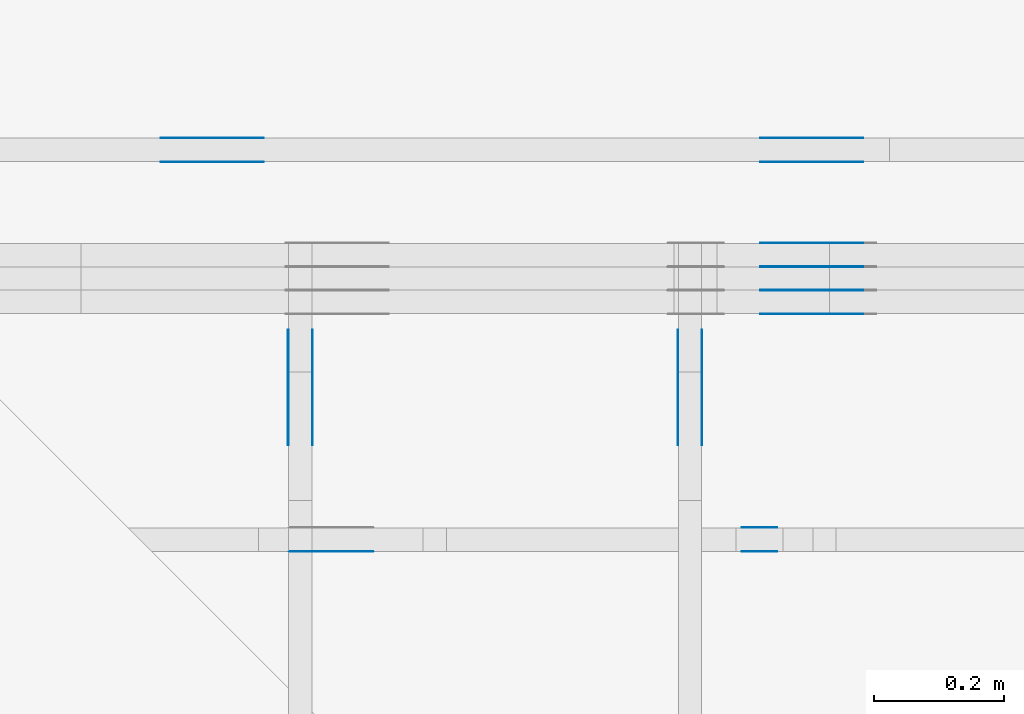
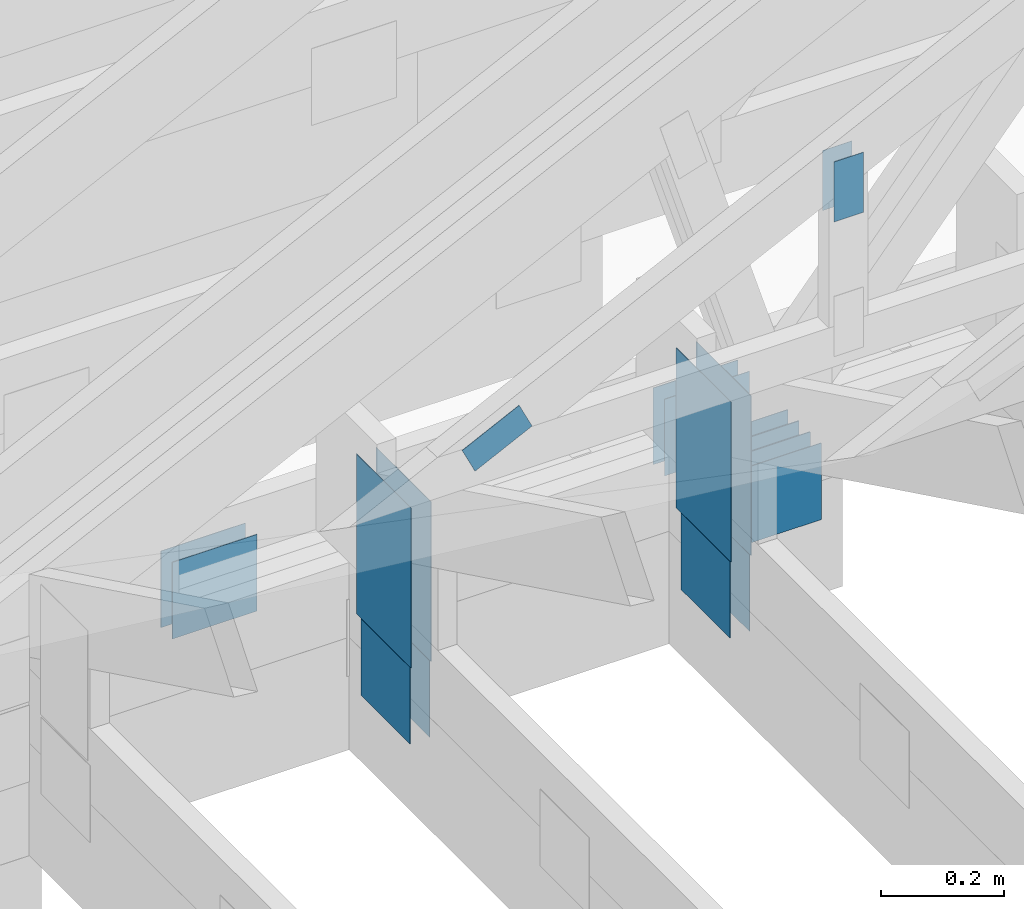
# One storey, part 100 of 159: 21 plates, 5 elements without a shape of their own.
"""IFC2X3 building model written with IfcOpenShell, lengths in millimetres."""

import ifcopenshell
import ifcopenshell.guid

model = None  # the IFC model being written
_history = None  # IfcOwnerHistory: only IFC2X3 demands one
_inside = {}  # id of a spatial element -> (the spatial element, [elements in it])
_under = {}  # id of a project, library or spatial element -> (it, [spatial elements below it])
_declared = {}  # id of a project -> (the project, [libraries it declares])
_typed = {}  # id of a type object -> (the type object, [elements of that type])
_made_of = {}  # id of a material, layer set ... -> (it, [elements and type objects made of it])


def new_model(schema):
    """Start an empty IFC model of exactly this schema.

    Asked for "IFC4X3", IfcOpenShell would pick the latest addendum, in which some entities
    have other attributes; the version numbers below select the first issue.
    IFC2X3 requires an IfcOwnerHistory on every rooted entity: one is made here for all.
    """
    global model, _history
    if schema == "IFC4X3":
        model = ifcopenshell.file(schema_version=(4, 3, 0, 0))
    else:
        model = ifcopenshell.file(schema=schema)
    _inside.clear()
    _under.clear()
    _declared.clear()
    _typed.clear()
    _made_of.clear()
    _history = None
    if model.schema == "IFC2X3":
        org = make("IfcOrganization", Name="unknown")
        user = make(
            "IfcPersonAndOrganization",
            ThePerson=make("IfcPerson", FamilyName="unknown"),
            TheOrganization=org,
        )
        app = make(
            "IfcApplication",
            ApplicationDeveloper=org,
            Version="unknown",
            ApplicationFullName="unknown",
            ApplicationIdentifier="unknown",
        )
        _history = make(
            "IfcOwnerHistory",
            OwningUser=user,
            OwningApplication=app,
            ChangeAction="ADDED",
            CreationDate=0,
        )
    return model


def make(cls, **values):
    """One entity of the class cls with the attributes given. An attribute that is None is left unset."""
    return model.create_entity(
        cls, **{name: value for name, value in values.items() if value is not None}
    )


def rooted(cls, **values):
    """An entity with a GlobalId (a new one), such as an element, a storey or a relation."""
    return make(cls, GlobalId=ifcopenshell.guid.new(), OwnerHistory=_history, **values)


def si_unit(unit_type, name, prefix=None):
    """IfcSIUnit, for example si_unit("LENGTHUNIT", "METRE", prefix="MILLI")."""
    return make("IfcSIUnit", UnitType=unit_type, Prefix=prefix, Name=name)


def assignment(units):
    """IfcUnitAssignment: the units of a project."""
    return None if units is None else make("IfcUnitAssignment", Units=units)


def point(xyz):
    """IfcCartesianPoint."""
    return None if xyz is None else make("IfcCartesianPoint", Coordinates=xyz)


def direction(xyz):
    """IfcDirection."""
    return None if xyz is None else make("IfcDirection", DirectionRatios=xyz)


def frame(location, z_axis=None, x_axis=None):
    """IfcAxis2Placement3D, a coordinate frame: its origin and axes. An axis left out is left unset."""
    return make(
        "IfcAxis2Placement3D",
        Location=point(location),
        Axis=direction(z_axis),
        RefDirection=direction(x_axis),
    )


def frame_2d(location, x_axis=None):
    """IfcAxis2Placement2D, a coordinate frame in the plane: its origin and x axis."""
    return make(
        "IfcAxis2Placement2D", Location=point(location), RefDirection=direction(x_axis)
    )


def origin():
    """The frame at (0, 0, 0) with its axes left unset."""
    return frame((0.0, 0.0, 0.0))


def origin_with_axes():
    """The frame at (0, 0, 0) with the z axis (0, 0, 1) and the x axis (1, 0, 0) written out."""
    return frame((0.0, 0.0, 0.0), z_axis=(0.0, 0.0, 1.0), x_axis=(1.0, 0.0, 0.0))


def origin_2d():
    """The frame at (0, 0) in the plane with its x axis left unset."""
    return frame_2d((0.0, 0.0))


def place(relative_to, where):
    """IfcLocalPlacement: puts the frame where relative to a parent placement (None: the world)."""
    return make(
        "IfcLocalPlacement", PlacementRelTo=relative_to, RelativePlacement=where
    )


def context(
    kind, dimensions, precision=None, world=None, true_north=None, identifier=None
):
    """IfcGeometricRepresentationContext, for example the 3D "Model" context."""
    return make(
        "IfcGeometricRepresentationContext",
        ContextIdentifier=identifier,
        ContextType=kind,
        CoordinateSpaceDimension=dimensions,
        Precision=precision,
        WorldCoordinateSystem=world,
        TrueNorth=true_north,
    )


def project(units=None, contexts=None):
    """IfcProject with its units and contexts."""
    return rooted(
        "IfcProject",
        Name="project",
        RepresentationContexts=contexts,
        UnitsInContext=assignment(units),
    )


def spatial(cls, under=None, at=None, **own):
    """A site, building, storey or space (cls), placed at a placement, below another one or the project."""
    s = rooted(cls, ObjectPlacement=at, **own)
    if under is not None:
        _under.setdefault(under.id(), (under, []))[1].append(s)
    return s


def faces_of(points, faces, orient=None, outer=None):
    """IfcFace entities. A face is a list of loops; a loop is a list of indices into points, from 0.

    orient and outer hold one flag for each loop. By default every Orientation is true, the
    first loop of a face is its IfcFaceOuterBound and the others are IfcFaceBound.
    """
    made = []
    for i, loops in enumerate(faces):
        bounds = []
        for j, loop in enumerate(loops):
            is_outer = j == 0 if outer is None else outer[i][j]
            bounds.append(
                make(
                    "IfcFaceOuterBound" if is_outer else "IfcFaceBound",
                    Bound=make("IfcPolyLoop", Polygon=[points[k] for k in loop]),
                    Orientation=True if orient is None else orient[i][j],
                )
            )
        made.append(make("IfcFace", Bounds=bounds))
    return made


def faceted_brep(points, faces, orient=None, outer=None, voids=None):
    """IfcFacetedBrep: a solid bounded by flat faces; with voids (closed shells), ...WithVoids."""
    shared = [point(p) for p in points]
    hull = make("IfcClosedShell", CfsFaces=faces_of(shared, faces, orient, outer))
    if voids is None:
        return make("IfcFacetedBrep", Outer=hull)
    return make(
        "IfcFacetedBrepWithVoids",
        Outer=hull,
        Voids=[
            make(cls, CfsFaces=faces_of(shared, fs, o, b)) for cls, fs, o, b in voids
        ],
    )


def shape(context_of_items, identifier, shape_type, items):
    """IfcShapeRepresentation: the items that make up one representation, for example the "Body"."""
    return make(
        "IfcShapeRepresentation",
        ContextOfItems=context_of_items,
        RepresentationIdentifier=identifier,
        RepresentationType=shape_type,
        Items=items,
    )


def made_of(thing, what):
    """Note that an element or type object is made of a material, layer set ...; save() writes the relation."""
    if what is not None:
        _made_of.setdefault(what.id(), (what, []))[1].append(thing)
    return thing


def element(
    cls,
    number,
    at=None,
    inside=None,
    cuts=None,
    type_object=None,
    material=None,
    context=None,
    identifier="Body",
    shape_type=None,
    held_by="IfcProductDefinitionShape",
    body=None,
    shapes=None,
    **own,
):
    """One element of the class cls, such as IfcWall. Its Tag is "e" and its number.

    at: its placement. inside: the storey or other place that contains it. cuts: it is an
    opening in that element (IfcRelVoidsElement). A single representation is given by context,
    identifier, shape_type and body (its items); several are given by shapes. held_by: the class
    of the entity that holds the representations. save() writes the other relations.
    """
    e = rooted(cls, Tag="e%d" % number, ObjectPlacement=at, **own)
    if body is not None:
        shapes = [shape(context, identifier, shape_type, body)]
    if shapes is not None:
        e.Representation = make(held_by, Representations=shapes)
    if inside is not None:
        _inside.setdefault(inside.id(), (inside, []))[1].append(e)
    if cuts is not None:
        rooted(
            "IfcRelVoidsElement", RelatingBuildingElement=cuts, RelatedOpeningElement=e
        )
    if type_object is not None:
        _typed.setdefault(type_object.id(), (type_object, []))[1].append(e)
    return made_of(e, material)


def aggregate(whole, parts):
    """IfcRelAggregates: a whole, such as a stair, and the parts it consists of."""
    return rooted("IfcRelAggregates", RelatingObject=whole, RelatedObjects=parts)


def save(model, path):
    """Write the relations noted so far, then the file.

    IfcRelAggregates (storeys below a building ...), IfcRelContainedInSpatialStructure (elements
    in a storey), IfcRelDefinesByType, IfcRelAssociatesMaterial and IfcRelDeclares: one each for
    every whole, place, type object, material and project.
    """
    for whole, parts in _under.values():
        aggregate(whole, parts)
    for where, things in _inside.values():
        rooted(
            "IfcRelContainedInSpatialStructure",
            RelatedElements=things,
            RelatingStructure=where,
        )
    for kind, things in _typed.values():
        rooted("IfcRelDefinesByType", RelatedObjects=things, RelatingType=kind)
    for what, things in _made_of.values():
        rooted("IfcRelAssociatesMaterial", RelatedObjects=things, RelatingMaterial=what)
    for by, libraries in _declared.values():
        rooted("IfcRelDeclares", RelatingContext=by, RelatedDefinitions=libraries)
    model.write(path)


model = new_model("IFC2X3")

# Units and contexts
model_context = context("Model", 3, precision=1e-05, world=origin())
plan_context = context("Plan", 2, precision=1e-05, world=origin_2d())
ifc_project = project(units=[si_unit("LENGTHUNIT", "METRE", prefix="MILLI"), si_unit("AREAUNIT", "SQUARE_METRE"), si_unit("VOLUMEUNIT", "CUBIC_METRE"), si_unit("SOLIDANGLEUNIT", "STERADIAN"), si_unit("PLANEANGLEUNIT", "RADIAN"), si_unit("MASSUNIT", "GRAM"), si_unit("TIMEUNIT", "SECOND"), si_unit("THERMODYNAMICTEMPERATUREUNIT", "DEGREE_CELSIUS"), si_unit("LUMINOUSINTENSITYUNIT", "LUMEN")], contexts=[model_context, plan_context])

# Site, building, storey
site_placement = place(None, origin_with_axes())
site = spatial("IfcSite", under=ifc_project, at=site_placement, CompositionType="ELEMENT")
building_placement = place(site_placement, origin_with_axes())
building = spatial("IfcBuilding", under=site, at=building_placement, Name="Plan 1", CompositionType="ELEMENT")
storey_placement = place(building_placement, origin_with_axes())
storey = spatial("IfcBuildingStorey", under=building, at=storey_placement, Name="Etasje 1", CompositionType="ELEMENT", Elevation=0.0)

# Assembly, plates
assembly_1_placement = place(storey_placement, frame((10700.012663101485, 8801.999999990367, 0.0), z_axis=(0.0, -1.0, 6.123031769111886e-17), x_axis=(1.0, 0.0, 0.0)))
assembly_1 = element("IfcElementAssembly", 1, at=assembly_1_placement, inside=storey, Name="T8 (1)", AssemblyPlace="FACTORY", PredefinedType="TRUSS")
plate_1_placement = place(assembly_1_placement, frame((1660.0, 299.0, 0.0), z_axis=(0.0, 0.0, 1.0), x_axis=(-1.0, 1.2246063538223773e-16, 0.0)))
plate_1 = element("IfcPlate", 2, at=plate_1_placement, Name="GNT100S 152x159", context=model_context, shape_type="Brep", body=[
    faceted_brep([(159.0, 152.00000000000003, 1.0), (0.0, 152.00000000000003, 1.0), (0.0, 0.0, 1.0), (159.0, 0.0, 1.0), (0.0, 152.00000000000003, 0.0), (159.0, 152.00000000000003, 1.9471241025775798e-14), (159.0, 5.684341886080802e-14, 1.9471241025775798e-14), (0.0, 5.684341886080802e-14, 0.0), (159.0, -2.92068615386637e-14, 5.2688860062695115e-30), (159.0, -2.914563122097258e-14, 1.0), (1.1247455413666031e-32, 6.123031769111886e-17, 1.0), (0.0, 0.0, 0.0), (159.0, 152.00000000000006, 0.0), (159.0, 152.00000000000006, 1.0), (159.0, 5.684341886080802e-14, 1.0), (159.0, 5.684341886080802e-14, 0.0), (0.0, 152.00000000000003, 0.0), (0.0, 152.00000000000003, 1.0), (159.0, 152.00000000000006, 1.0), (159.0, 152.00000000000006, 0.0), (0.0, 0.0, 0.0), (6.123031769111886e-17, -7.498303609110687e-33, 1.0), (1.8675246895791256e-14, 152.00000000000003, 1.0), (1.8614016578100137e-14, 152.00000000000003, -1.1397421485848246e-30)], [[[0, 1, 2, 3]], [[4, 5, 6, 7]], [[8, 9, 10, 11]], [[12, 13, 14, 15]], [[16, 17, 18, 19]], [[20, 21, 22, 23]]]),
])
plate_2_placement = place(assembly_1_placement, frame((1660.0, 299.0, -37.0), z_axis=(0.0, 0.0, 1.0), x_axis=(-1.0, 1.2246063538223773e-16, 0.0)))
plate_2 = element("IfcPlate", 3, at=plate_2_placement, Name="GNT100S 152x159", context=model_context, shape_type="Brep", body=[
    faceted_brep([(159.0, 152.00000000000003, 1.0), (0.0, 152.00000000000003, 1.0), (0.0, 0.0, 1.0), (159.0, 0.0, 1.0), (0.0, 152.00000000000003, 0.0), (159.0, 152.00000000000003, 1.9471241025775798e-14), (159.0, 5.684341886080802e-14, 1.9471241025775798e-14), (0.0, 5.684341886080802e-14, 0.0), (159.0, -2.92068615386637e-14, 5.2688860062695115e-30), (159.0, -2.914563122097258e-14, 1.0), (1.1247455413666031e-32, 6.123031769111886e-17, 1.0), (0.0, 0.0, 0.0), (159.0, 152.00000000000006, 0.0), (159.0, 152.00000000000006, 1.0), (159.0, 5.684341886080802e-14, 1.0), (159.0, 5.684341886080802e-14, 0.0), (0.0, 152.00000000000003, 0.0), (0.0, 152.00000000000003, 1.0), (159.0, 152.00000000000006, 1.0), (159.0, 152.00000000000006, 0.0), (0.0, 0.0, 0.0), (6.123031769111886e-17, -7.498303609110687e-33, 1.0), (1.8675246895791256e-14, 152.00000000000003, 1.0), (1.8614016578100137e-14, 152.00000000000003, -1.1397421485848246e-30)], [[[0, 1, 2, 3]], [[4, 5, 6, 7]], [[8, 9, 10, 11]], [[12, 13, 14, 15]], [[16, 17, 18, 19]], [[20, 21, 22, 23]]]),
])
plate_3_placement = place(assembly_1_placement, frame((1660.0, 299.0, -36.0), z_axis=(0.0, 0.0, 1.0), x_axis=(-1.0, 1.2246063538223773e-16, 0.0)))
plate_3 = element("IfcPlate", 4, at=plate_3_placement, Name="GNT100S 152x159", context=model_context, shape_type="Brep", body=[
    faceted_brep([(159.0, 152.00000000000003, 1.0), (0.0, 152.00000000000003, 1.0), (0.0, 0.0, 1.0), (159.0, 0.0, 1.0), (0.0, 152.00000000000003, 0.0), (159.0, 152.00000000000003, 1.9471241025775798e-14), (159.0, 5.684341886080802e-14, 1.9471241025775798e-14), (0.0, 5.684341886080802e-14, 0.0), (159.0, -2.92068615386637e-14, 5.2688860062695115e-30), (159.0, -2.914563122097258e-14, 1.0), (1.1247455413666031e-32, 6.123031769111886e-17, 1.0), (0.0, 0.0, 0.0), (159.0, 152.00000000000006, 0.0), (159.0, 152.00000000000006, 1.0), (159.0, 5.684341886080802e-14, 1.0), (159.0, 5.684341886080802e-14, 0.0), (0.0, 152.00000000000003, 0.0), (0.0, 152.00000000000003, 1.0), (159.0, 152.00000000000006, 1.0), (159.0, 152.00000000000006, 0.0), (0.0, 0.0, 0.0), (6.123031769111886e-17, -7.498303609110687e-33, 1.0), (1.8675246895791256e-14, 152.00000000000003, 1.0), (1.8614016578100137e-14, 152.00000000000003, -1.1397421485848246e-30)], [[[0, 1, 2, 3]], [[4, 5, 6, 7]], [[8, 9, 10, 11]], [[12, 13, 14, 15]], [[16, 17, 18, 19]], [[20, 21, 22, 23]]]),
])
plate_4_placement = place(assembly_1_placement, frame((1660.0, 299.0, -73.0), z_axis=(0.0, 0.0, 1.0), x_axis=(-1.0, 1.2246063538223773e-16, 0.0)))
plate_4 = element("IfcPlate", 5, at=plate_4_placement, Name="GNT100S 152x159", context=model_context, shape_type="Brep", body=[
    faceted_brep([(159.0, 152.00000000000003, 1.0), (0.0, 152.00000000000003, 1.0), (0.0, 0.0, 1.0), (159.0, 0.0, 1.0), (0.0, 152.00000000000003, 0.0), (159.0, 152.00000000000003, 1.9471241025775798e-14), (159.0, 5.684341886080802e-14, 1.9471241025775798e-14), (0.0, 5.684341886080802e-14, 0.0), (159.0, -2.92068615386637e-14, 5.2688860062695115e-30), (159.0, -2.914563122097258e-14, 1.0), (1.1247455413666031e-32, 6.123031769111886e-17, 1.0), (0.0, 0.0, 0.0), (159.0, 152.00000000000006, 0.0), (159.0, 152.00000000000006, 1.0), (159.0, 5.684341886080802e-14, 1.0), (159.0, 5.684341886080802e-14, 0.0), (0.0, 152.00000000000003, 0.0), (0.0, 152.00000000000003, 1.0), (159.0, 152.00000000000006, 1.0), (159.0, 152.00000000000006, 0.0), (0.0, 0.0, 0.0), (6.123031769111886e-17, -7.498303609110687e-33, 1.0), (1.8675246895791256e-14, 152.00000000000003, 1.0), (1.8614016578100137e-14, 152.00000000000003, -1.1397421485848246e-30)], [[[0, 1, 2, 3]], [[4, 5, 6, 7]], [[8, 9, 10, 11]], [[12, 13, 14, 15]], [[16, 17, 18, 19]], [[20, 21, 22, 23]]]),
])
plate_5_placement = place(assembly_1_placement, frame((1660.0, 299.0, -72.0), z_axis=(0.0, 0.0, 1.0), x_axis=(-1.0, 1.2246063538223773e-16, 0.0)))
plate_5 = element("IfcPlate", 6, at=plate_5_placement, Name="GNT100S 152x159", context=model_context, shape_type="Brep", body=[
    faceted_brep([(159.0, 152.00000000000003, 1.0), (0.0, 152.00000000000003, 1.0), (0.0, 0.0, 1.0), (159.0, 0.0, 1.0), (0.0, 152.00000000000003, 0.0), (159.0, 152.00000000000003, 1.9471241025775798e-14), (159.0, 5.684341886080802e-14, 1.9471241025775798e-14), (0.0, 5.684341886080802e-14, 0.0), (159.0, -2.92068615386637e-14, 5.2688860062695115e-30), (159.0, -2.914563122097258e-14, 1.0), (1.1247455413666031e-32, 6.123031769111886e-17, 1.0), (0.0, 0.0, 0.0), (159.0, 152.00000000000006, 0.0), (159.0, 152.00000000000006, 1.0), (159.0, 5.684341886080802e-14, 1.0), (159.0, 5.684341886080802e-14, 0.0), (0.0, 152.00000000000003, 0.0), (0.0, 152.00000000000003, 1.0), (159.0, 152.00000000000006, 1.0), (159.0, 152.00000000000006, 0.0), (0.0, 0.0, 0.0), (6.123031769111886e-17, -7.498303609110687e-33, 1.0), (1.8675246895791256e-14, 152.00000000000003, 1.0), (1.8614016578100137e-14, 152.00000000000003, -1.1397421485848246e-30)], [[[0, 1, 2, 3]], [[4, 5, 6, 7]], [[8, 9, 10, 11]], [[12, 13, 14, 15]], [[16, 17, 18, 19]], [[20, 21, 22, 23]]]),
])
plate_6_placement = place(assembly_1_placement, frame((1660.0, 299.0, -109.0), z_axis=(0.0, 0.0, 1.0), x_axis=(-1.0, 1.2246063538223773e-16, 0.0)))
plate_6 = element("IfcPlate", 7, at=plate_6_placement, Name="GNT100S 152x159", context=model_context, shape_type="Brep", body=[
    faceted_brep([(159.0, 152.00000000000003, 1.0), (0.0, 152.00000000000003, 1.0), (0.0, 0.0, 1.0), (159.0, 0.0, 1.0), (0.0, 152.00000000000003, 0.0), (159.0, 152.00000000000003, 1.9471241025775798e-14), (159.0, 5.684341886080802e-14, 1.9471241025775798e-14), (0.0, 5.684341886080802e-14, 0.0), (159.0, -2.92068615386637e-14, 5.2688860062695115e-30), (159.0, -2.914563122097258e-14, 1.0), (1.1247455413666031e-32, 6.123031769111886e-17, 1.0), (0.0, 0.0, 0.0), (159.0, 152.00000000000006, 0.0), (159.0, 152.00000000000006, 1.0), (159.0, 5.684341886080802e-14, 1.0), (159.0, 5.684341886080802e-14, 0.0), (0.0, 152.00000000000003, 0.0), (0.0, 152.00000000000003, 1.0), (159.0, 152.00000000000006, 1.0), (159.0, 152.00000000000006, 0.0), (0.0, 0.0, 0.0), (6.123031769111886e-17, -7.498303609110687e-33, 1.0), (1.8675246895791256e-14, 152.00000000000003, 1.0), (1.8614016578100137e-14, 152.00000000000003, -1.1397421485848246e-30)], [[[0, 1, 2, 3]], [[4, 5, 6, 7]], [[8, 9, 10, 11]], [[12, 13, 14, 15]], [[16, 17, 18, 19]], [[20, 21, 22, 23]]]),
])
aggregate(assembly_1, [plate_1, plate_2, plate_3, plate_4, plate_5, plate_6])

assembly_2_placement = place(storey_placement, frame((10000.012663278096, 9072.000080051337, 1.1021457184401395e-15), z_axis=(9.811600543477555e-09, 1.0, 6.123031769111886e-17), x_axis=(-1.0, 9.811600543477555e-09, 0.0)))
assembly_2 = element("IfcElementAssembly", 8, at=assembly_2_placement, inside=storey, Name="T9 (79)", AssemblyPlace="FACTORY", PredefinedType="TRUSS")
plate_7_placement = place(assembly_2_placement, frame((-2360.0, 147.0, 0.0), z_axis=(0.0, 0.0, 1.0), x_axis=(1.0, 0.0, 0.0)))
plate_7 = element("IfcPlate", 9, at=plate_7_placement, Name="GNT100S 152x159", context=model_context, shape_type="Brep", body=[
    faceted_brep([(159.0, 152.0, 1.0), (0.0, 152.0, 1.0), (0.0, 0.0, 1.0), (159.0, 0.0, 1.0), (0.0, 152.0, 0.0), (159.0, 152.0, 1.9471241025775798e-14), (159.0, 0.0, 1.9471241025775798e-14), (0.0, 0.0, 0.0), (159.0, 3.373933274962177e-10, 1.788345410772899e-30), (159.0, 3.373933887265354e-10, 1.0), (1.1247455413666031e-32, 3.3742259558807407e-10, 1.0), (0.0, 3.374225343577564e-10, 0.0), (159.0, 152.00000000033742, 0.0), (159.0, 152.00000000033742, 1.0), (159.0, 3.374225343577564e-10, 1.0), (159.0, 3.374225343577564e-10, 0.0), (0.0, 152.00000000033742, 0.0), (-3.7491518045553436e-33, 152.00000000033742, 1.0), (159.0, 152.00000000033742, 1.0), (159.0, 152.00000000033742, 0.0), (4.1320977949735785e-26, 3.374225343577564e-10, -2.5300966071700395e-42), (6.123031773243984e-17, 3.374225343577564e-10, 1.0), (1.8675246895832574e-14, 152.00000000033742, 1.0), (1.8614016578141455e-14, 152.00000000033742, -1.1397421485873545e-30)], [[[0, 1, 2, 3]], [[4, 5, 6, 7]], [[8, 9, 10, 11]], [[12, 13, 14, 15]], [[16, 17, 18, 19]], [[20, 21, 22, 23]]]),
])
plate_8_placement = place(assembly_2_placement, frame((-2360.0, 147.0, -37.0), z_axis=(0.0, 0.0, 1.0), x_axis=(1.0, 0.0, 0.0)))
plate_8 = element("IfcPlate", 10, at=plate_8_placement, Name="GNT100S 152x159", context=model_context, shape_type="Brep", body=[
    faceted_brep([(159.0, 152.0, 1.0), (0.0, 152.0, 1.0), (0.0, 0.0, 1.0), (159.0, 0.0, 1.0), (0.0, 152.0, 0.0), (159.0, 152.0, 1.9471241025775798e-14), (159.0, 0.0, 1.9471241025775798e-14), (0.0, 0.0, 0.0), (159.0, 3.373933274962177e-10, 1.788345410772899e-30), (159.0, 3.373933887265354e-10, 1.0), (1.1247455413666031e-32, 3.3742259558807407e-10, 1.0), (0.0, 3.374225343577564e-10, 0.0), (159.0, 152.00000000033742, 0.0), (159.0, 152.00000000033742, 1.0), (159.0, 3.374225343577564e-10, 1.0), (159.0, 3.374225343577564e-10, 0.0), (0.0, 152.00000000033742, 0.0), (-3.7491518045553436e-33, 152.00000000033742, 1.0), (159.0, 152.00000000033742, 1.0), (159.0, 152.00000000033742, 0.0), (4.1320977949735785e-26, 3.374225343577564e-10, -2.5300966071700395e-42), (6.123031773243984e-17, 3.374225343577564e-10, 1.0), (1.8675246895832574e-14, 152.00000000033742, 1.0), (1.8614016578141455e-14, 152.00000000033742, -1.1397421485873545e-30)], [[[0, 1, 2, 3]], [[4, 5, 6, 7]], [[8, 9, 10, 11]], [[12, 13, 14, 15]], [[16, 17, 18, 19]], [[20, 21, 22, 23]]]),
])
plate_9_placement = place(assembly_2_placement, frame((-1436.851318359375, 147.0, 0.0), z_axis=(0.0, 0.0, 1.0), x_axis=(1.0, 0.0, 0.0)))
plate_9 = element("IfcPlate", 11, at=plate_9_placement, Name="GNT100S 152x159", context=model_context, shape_type="Brep", body=[
    faceted_brep([(159.0, 152.0, 1.0), (0.0, 152.0, 1.0), (0.0, 0.0, 1.0), (159.0, 0.0, 1.0), (0.0, 152.0, 0.0), (159.0, 152.0, 1.9471241025775798e-14), (159.0, 0.0, 1.9471241025775798e-14), (0.0, 0.0, 0.0), (159.00003606200744, 6.143913075983109e-10, 1.788345816381587e-30), (159.00003606200744, 6.143913688286286e-10, 1.0), (3.606200743888621e-05, 6.144205756901673e-10, 1.0), (3.606200743888621e-05, 6.144205144598496e-10, 4.056086879372978e-37), (159.00003606200744, 152.00000000061442, 0.0), (159.00003606200744, 152.00000000061442, 1.0), (159.00003606200744, 6.144205144664738e-10, 1.0), (159.00003606200744, 6.144205144664738e-10, 0.0), (3.606200743888621e-05, 152.00000000061442, 0.0), (3.606200743888621e-05, 152.00000000061442, 1.0), (159.00003606200744, 152.00000000061442, 1.0), (159.00003606200744, 152.00000000061442, 0.0), (3.606200743888621e-05, 6.144205144664738e-10, 0.0), (3.606200743894744e-05, 6.144205144664738e-10, 1.0), (3.606200745756146e-05, 152.00000000061442, 1.0), (3.606200745750023e-05, 152.00000000061442, -1.1397420192804459e-30)], [[[0, 1, 2, 3]], [[4, 5, 6, 7]], [[8, 9, 10, 11]], [[12, 13, 14, 15]], [[16, 17, 18, 19]], [[20, 21, 22, 23]]]),
])
plate_10_placement = place(assembly_2_placement, frame((-1436.851318359375, 147.0, -37.0), z_axis=(0.0, 0.0, 1.0), x_axis=(1.0, 0.0, 0.0)))
plate_10 = element("IfcPlate", 12, at=plate_10_placement, Name="GNT100S 152x159", context=model_context, shape_type="Brep", body=[
    faceted_brep([(159.0, 152.0, 1.0), (0.0, 152.0, 1.0), (0.0, 0.0, 1.0), (159.0, 0.0, 1.0), (0.0, 152.0, 0.0), (159.0, 152.0, 1.9471241025775798e-14), (159.0, 0.0, 1.9471241025775798e-14), (0.0, 0.0, 0.0), (159.00003606200744, 6.143913075983109e-10, 1.788345816381587e-30), (159.00003606200744, 6.143913688286286e-10, 1.0), (3.606200743888621e-05, 6.144205756901673e-10, 1.0), (3.606200743888621e-05, 6.144205144598496e-10, 4.056086879372978e-37), (159.00003606200744, 152.00000000061442, 0.0), (159.00003606200744, 152.00000000061442, 1.0), (159.00003606200744, 6.144205144664738e-10, 1.0), (159.00003606200744, 6.144205144664738e-10, 0.0), (3.606200743888621e-05, 152.00000000061442, 0.0), (3.606200743888621e-05, 152.00000000061442, 1.0), (159.00003606200744, 152.00000000061442, 1.0), (159.00003606200744, 152.00000000061442, 0.0), (3.606200743888621e-05, 6.144205144664738e-10, 0.0), (3.606200743894744e-05, 6.144205144664738e-10, 1.0), (3.606200745756146e-05, 152.00000000061442, 1.0), (3.606200745750023e-05, 152.00000000061442, -1.1397420192804459e-30)], [[[0, 1, 2, 3]], [[4, 5, 6, 7]], [[8, 9, 10, 11]], [[12, 13, 14, 15]], [[16, 17, 18, 19]], [[20, 21, 22, 23]]]),
])
aggregate(assembly_2, [plate_7, plate_8, plate_9, plate_10])

assembly_3_placement = place(storey_placement, frame((12075.022261404752, -699.9989301294854, 4.558494966049043e-13), z_axis=(-1.0, 1.836909530733566e-16, 6.123031769111886e-17), x_axis=(-1.836909530733566e-16, -1.0, 0.0)))
assembly_3 = element("IfcElementAssembly", 13, at=assembly_3_placement, inside=storey, Name="T5 (98)", AssemblyPlace="FACTORY", PredefinedType="TRUSS")
plate_11_placement = place(assembly_3_placement, frame((-9461.9990234375, 132.2982177734375, 0.0), z_axis=(0.0, 0.0, 1.0), x_axis=(1.0, 0.0, 0.0)))
plate_11 = element("IfcPlate", 14, at=plate_11_placement, Name="GNT100S 152x159", context=model_context, shape_type="Brep", body=[
    faceted_brep([(159.0, 152.0, 1.0), (0.0, 152.0, 1.0), (0.0, 0.0, 1.0), (159.0, 0.0, 1.0), (0.0, 152.0, 0.0), (159.0, 152.0, 1.9471241025775798e-14), (159.0, 0.0, 1.9471241025775798e-14), (0.0, 0.0, 0.0), (159.00009331759065, -2.9206878680260863e-14, 1.7883464603583392e-30), (159.00009331759065, -2.9145648362569744e-14, 1.0), (9.331759065389633e-05, 6.121317609395314e-17, 1.0), (9.331759065389633e-05, -1.714159716572357e-20, 1.0495854401904369e-36), (159.00009331759065, 152.0, 0.0), (159.00009331759065, 152.0, 1.0), (159.00009331759065, 0.0, 1.0), (159.00009331759065, 0.0, 0.0), (9.331759065389633e-05, 152.0, 0.0), (9.331759065389633e-05, 152.0, 1.0), (159.00009331759065, 152.0, 1.0), (159.00009331759065, 152.0, 0.0), (9.331759065389633e-05, 0.0, 0.0), (9.331759065395756e-05, -7.498303609110687e-33, 1.0), (9.331759067257158e-05, 152.0, 1.0), (9.331759067251035e-05, 152.0, -1.1397420192804459e-30)], [[[0, 1, 2, 3]], [[4, 5, 6, 7]], [[8, 9, 10, 11]], [[12, 13, 14, 15]], [[16, 17, 18, 19]], [[20, 21, 22, 23]]]),
])
plate_12_placement = place(assembly_3_placement, frame((-9461.9990234375, 132.2982177734375, -37.0), z_axis=(0.0, 0.0, 1.0), x_axis=(1.0, 0.0, 0.0)))
plate_12 = element("IfcPlate", 15, at=plate_12_placement, Name="GNT100S 152x159", context=model_context, shape_type="Brep", body=[
    faceted_brep([(159.0, 152.0, 1.0), (0.0, 152.0, 1.0), (0.0, 0.0, 1.0), (159.0, 0.0, 1.0), (0.0, 152.0, 0.0), (159.0, 152.0, 1.9471241025775798e-14), (159.0, 0.0, 1.9471241025775798e-14), (0.0, 0.0, 0.0), (159.00009331759065, -2.9206878680260863e-14, 1.7883464603583392e-30), (159.00009331759065, -2.9145648362569744e-14, 1.0), (9.331759065389633e-05, 6.121317609395314e-17, 1.0), (9.331759065389633e-05, -1.714159716572357e-20, 1.0495854401904369e-36), (159.00009331759065, 152.0, 0.0), (159.00009331759065, 152.0, 1.0), (159.00009331759065, 0.0, 1.0), (159.00009331759065, 0.0, 0.0), (9.331759065389633e-05, 152.0, 0.0), (9.331759065389633e-05, 152.0, 1.0), (159.00009331759065, 152.0, 1.0), (159.00009331759065, 152.0, 0.0), (9.331759065389633e-05, 0.0, 0.0), (9.331759065395756e-05, -7.498303609110687e-33, 1.0), (9.331759067257158e-05, 152.0, 1.0), (9.331759067251035e-05, 152.0, -1.1397420192804459e-30)], [[[0, 1, 2, 3]], [[4, 5, 6, 7]], [[8, 9, 10, 11]], [[12, 13, 14, 15]], [[16, 17, 18, 19]], [[20, 21, 22, 23]]]),
])
plate_13_placement = place(assembly_3_placement, frame((-9477.154435624892, 601.947714222237, 0.0), z_axis=(0.0, 0.0, 1.0), x_axis=(2.6073089813474087e-12, -1.0, 0.0)))
plate_13 = element("IfcPlate", 16, at=plate_13_placement, Name="GNT100S 178x317", context=model_context, shape_type="Brep", body=[
    faceted_brep([(316.9999908340292, 178.00013874989236, 1.0), (2.1351607301767217e-05, 178.00013874989236, 1.0), (2.1351143232095637e-05, 0.00013874989235773683, 1.0), (316.99999083356505, 0.00013874989235773683, 1.0), (2.1351607301767217e-05, 178.00013874989236, 2.61473139660644e-21), (316.9999908340292, 178.00013874989236, 3.882002029369875e-14), (316.99999083356505, 0.0001387490647175582, 3.882002029364191e-14), (2.1351143232095637e-05, 0.0001387490647175582, 2.6146745663395966e-21), (317.00000000000006, -2.1010854189297505e-13, 1.286501276972462e-29), (317.00000000000006, -2.1004731157528393e-13, 1.0), (1.1368683772161603e-13, 1.8190506338635476e-12, 1.0), (1.1368683772161603e-13, 1.8189894035458565e-12, 0.0), (317.00000000000006, 178.0, 0.0), (317.00000000000006, 178.0, 1.0), (317.00000000000006, 0.0, 1.0), (317.00000000000006, 0.0, 0.0), (0.0, 178.00000000000182, 0.0), (0.0, 178.00000000000182, 1.0), (317.00000000000006, 177.99999999999997, 1.0), (317.00000000000006, 177.99999999999997, -1.5777218104420236e-30), (1.1368683772161664e-13, 1.8189894035458565e-12, -3.6433760072445244e-44), (1.1374806803930775e-13, 1.8189894035458565e-12, 1.0), (5.6498181784034924e-14, 178.00000000000182, 1.0), (5.6436951466343805e-14, 178.00000000000182, -3.455652467802488e-30)], [[[0, 1, 2, 3]], [[4, 5, 6, 7]], [[8, 9, 10, 11]], [[12, 13, 14, 15]], [[16, 17, 18, 19]], [[20, 21, 22, 23]]]),
])
plate_14_placement = place(assembly_3_placement, frame((-9477.154435624892, 601.947714222237, -37.0), z_axis=(0.0, 0.0, 1.0), x_axis=(2.6073089813474087e-12, -1.0, 0.0)))
plate_14 = element("IfcPlate", 17, at=plate_14_placement, Name="GNT100S 178x317", context=model_context, shape_type="Brep", body=[
    faceted_brep([(316.9999908340292, 178.00013874989236, 1.0), (2.1351607301767217e-05, 178.00013874989236, 1.0), (2.1351143232095637e-05, 0.00013874989235773683, 1.0), (316.99999083356505, 0.00013874989235773683, 1.0), (2.1351607301767217e-05, 178.00013874989236, 2.61473139660644e-21), (316.9999908340292, 178.00013874989236, 3.882002029369875e-14), (316.99999083356505, 0.0001387490647175582, 3.882002029364191e-14), (2.1351143232095637e-05, 0.0001387490647175582, 2.6146745663395966e-21), (317.00000000000006, -2.1010854189297505e-13, 1.286501276972462e-29), (317.00000000000006, -2.1004731157528393e-13, 1.0), (1.1368683772161603e-13, 1.8190506338635476e-12, 1.0), (1.1368683772161603e-13, 1.8189894035458565e-12, 0.0), (317.00000000000006, 178.0, 0.0), (317.00000000000006, 178.0, 1.0), (317.00000000000006, 0.0, 1.0), (317.00000000000006, 0.0, 0.0), (0.0, 178.00000000000182, 0.0), (0.0, 178.00000000000182, 1.0), (317.00000000000006, 177.99999999999997, 1.0), (317.00000000000006, 177.99999999999997, -1.5777218104420236e-30), (1.1368683772161664e-13, 1.8189894035458565e-12, -3.6433760072445244e-44), (1.1374806803930775e-13, 1.8189894035458565e-12, 1.0), (5.6498181784034924e-14, 178.00000000000182, 1.0), (5.6436951466343805e-14, 178.00000000000182, -3.455652467802488e-30)], [[[0, 1, 2, 3]], [[4, 5, 6, 7]], [[8, 9, 10, 11]], [[12, 13, 14, 15]], [[16, 17, 18, 19]], [[20, 21, 22, 23]]]),
])
aggregate(assembly_3, [plate_11, plate_12, plate_13, plate_14])

assembly_4_placement = place(storey_placement, frame((11475.022261404752, -699.9989301294845, 1.1021457184401395e-15), z_axis=(-1.0, 1.836909530733566e-16, 6.123031769111886e-17), x_axis=(-1.836909530733566e-16, -1.0, 0.0)))
assembly_4 = element("IfcElementAssembly", 18, at=assembly_4_placement, inside=storey, Name="T5 (97)", AssemblyPlace="FACTORY", PredefinedType="TRUSS")
plate_15_placement = place(assembly_4_placement, frame((-9461.9990234375, 132.2982177734375, 0.0), z_axis=(0.0, 0.0, 1.0), x_axis=(1.0, 0.0, 0.0)))
plate_15 = element("IfcPlate", 19, at=plate_15_placement, Name="GNT100S 152x159", context=model_context, shape_type="Brep", body=[
    faceted_brep([(159.0, 152.0, 1.0), (0.0, 152.0, 1.0), (0.0, 0.0, 1.0), (159.0, 0.0, 1.0), (0.0, 152.0, 0.0), (159.0, 152.0, 1.9471241025775798e-14), (159.0, 0.0, 1.9471241025775798e-14), (0.0, 0.0, 0.0), (159.00009331759065, -2.9206878680260863e-14, 1.7883464603583392e-30), (159.00009331759065, -2.9145648362569744e-14, 1.0), (9.331759065389633e-05, 6.121317609395314e-17, 1.0), (9.331759065389633e-05, -1.714159716572357e-20, 1.0495854401904369e-36), (159.00009331759065, 152.0, 0.0), (159.00009331759065, 152.0, 1.0), (159.00009331759065, 0.0, 1.0), (159.00009331759065, 0.0, 0.0), (9.331759065389633e-05, 152.0, 0.0), (9.331759065389633e-05, 152.0, 1.0), (159.00009331759065, 152.0, 1.0), (159.00009331759065, 152.0, 0.0), (9.331759065389633e-05, 0.0, 0.0), (9.331759065395756e-05, -7.498303609110687e-33, 1.0), (9.331759067257158e-05, 152.0, 1.0), (9.331759067251035e-05, 152.0, -1.1397420192804459e-30)], [[[0, 1, 2, 3]], [[4, 5, 6, 7]], [[8, 9, 10, 11]], [[12, 13, 14, 15]], [[16, 17, 18, 19]], [[20, 21, 22, 23]]]),
])
plate_16_placement = place(assembly_4_placement, frame((-9461.9990234375, 132.2982177734375, -37.0), z_axis=(0.0, 0.0, 1.0), x_axis=(1.0, 0.0, 0.0)))
plate_16 = element("IfcPlate", 20, at=plate_16_placement, Name="GNT100S 152x159", context=model_context, shape_type="Brep", body=[
    faceted_brep([(159.0, 152.0, 1.0), (0.0, 152.0, 1.0), (0.0, 0.0, 1.0), (159.0, 0.0, 1.0), (0.0, 152.0, 0.0), (159.0, 152.0, 1.9471241025775798e-14), (159.0, 0.0, 1.9471241025775798e-14), (0.0, 0.0, 0.0), (159.00009331759065, -2.9206878680260863e-14, 1.7883464603583392e-30), (159.00009331759065, -2.9145648362569744e-14, 1.0), (9.331759065389633e-05, 6.121317609395314e-17, 1.0), (9.331759065389633e-05, -1.714159716572357e-20, 1.0495854401904369e-36), (159.00009331759065, 152.0, 0.0), (159.00009331759065, 152.0, 1.0), (159.00009331759065, 0.0, 1.0), (159.00009331759065, 0.0, 0.0), (9.331759065389633e-05, 152.0, 0.0), (9.331759065389633e-05, 152.0, 1.0), (159.00009331759065, 152.0, 1.0), (159.00009331759065, 152.0, 0.0), (9.331759065389633e-05, 0.0, 0.0), (9.331759065395756e-05, -7.498303609110687e-33, 1.0), (9.331759067257158e-05, 152.0, 1.0), (9.331759067251035e-05, 152.0, -1.1397420192804459e-30)], [[[0, 1, 2, 3]], [[4, 5, 6, 7]], [[8, 9, 10, 11]], [[12, 13, 14, 15]], [[16, 17, 18, 19]], [[20, 21, 22, 23]]]),
])
plate_17_placement = place(assembly_4_placement, frame((-9477.154435624892, 601.947714222237, 0.0), z_axis=(0.0, 0.0, 1.0), x_axis=(2.6073089813474087e-12, -1.0, 0.0)))
plate_17 = element("IfcPlate", 21, at=plate_17_placement, Name="GNT100S 178x317", context=model_context, shape_type="Brep", body=[
    faceted_brep([(316.9999908340292, 178.00013874989236, 1.0), (2.1351607301767217e-05, 178.00013874989236, 1.0), (2.1351143232095637e-05, 0.00013874989235773683, 1.0), (316.99999083356505, 0.00013874989235773683, 1.0), (2.1351607301767217e-05, 178.00013874989236, 2.61473139660644e-21), (316.9999908340292, 178.00013874989236, 3.882002029369875e-14), (316.99999083356505, 0.0001387490647175582, 3.882002029364191e-14), (2.1351143232095637e-05, 0.0001387490647175582, 2.6146745663395966e-21), (317.00000000000006, -2.1010854189297505e-13, 1.286501276972462e-29), (317.00000000000006, -2.1004731157528393e-13, 1.0), (1.1368683772161603e-13, 1.8190506338635476e-12, 1.0), (1.1368683772161603e-13, 1.8189894035458565e-12, 0.0), (317.00000000000006, 178.0, 0.0), (317.00000000000006, 178.0, 1.0), (317.00000000000006, 0.0, 1.0), (317.00000000000006, 0.0, 0.0), (0.0, 178.00000000000182, 0.0), (0.0, 178.00000000000182, 1.0), (317.00000000000006, 177.99999999999997, 1.0), (317.00000000000006, 177.99999999999997, -1.5777218104420236e-30), (1.1368683772161664e-13, 1.8189894035458565e-12, -3.6433760072445244e-44), (1.1374806803930775e-13, 1.8189894035458565e-12, 1.0), (5.6498181784034924e-14, 178.00000000000182, 1.0), (5.6436951466343805e-14, 178.00000000000182, -3.455652467802488e-30)], [[[0, 1, 2, 3]], [[4, 5, 6, 7]], [[8, 9, 10, 11]], [[12, 13, 14, 15]], [[16, 17, 18, 19]], [[20, 21, 22, 23]]]),
])
plate_18_placement = place(assembly_4_placement, frame((-9477.154435624892, 601.947714222237, -37.0), z_axis=(0.0, 0.0, 1.0), x_axis=(2.6073089813474087e-12, -1.0, 0.0)))
plate_18 = element("IfcPlate", 22, at=plate_18_placement, Name="GNT100S 178x317", context=model_context, shape_type="Brep", body=[
    faceted_brep([(316.9999908340292, 178.00013874989236, 1.0), (2.1351607301767217e-05, 178.00013874989236, 1.0), (2.1351143232095637e-05, 0.00013874989235773683, 1.0), (316.99999083356505, 0.00013874989235773683, 1.0), (2.1351607301767217e-05, 178.00013874989236, 2.61473139660644e-21), (316.9999908340292, 178.00013874989236, 3.882002029369875e-14), (316.99999083356505, 0.0001387490647175582, 3.882002029364191e-14), (2.1351143232095637e-05, 0.0001387490647175582, 2.6146745663395966e-21), (317.00000000000006, -2.1010854189297505e-13, 1.286501276972462e-29), (317.00000000000006, -2.1004731157528393e-13, 1.0), (1.1368683772161603e-13, 1.8190506338635476e-12, 1.0), (1.1368683772161603e-13, 1.8189894035458565e-12, 0.0), (317.00000000000006, 178.0, 0.0), (317.00000000000006, 178.0, 1.0), (317.00000000000006, 0.0, 1.0), (317.00000000000006, 0.0, 0.0), (0.0, 178.00000000000182, 0.0), (0.0, 178.00000000000182, 1.0), (317.00000000000006, 177.99999999999997, 1.0), (317.00000000000006, 177.99999999999997, -1.5777218104420236e-30), (1.1368683772161664e-13, 1.8189894035458565e-12, -3.6433760072445244e-44), (1.1374806803930775e-13, 1.8189894035458565e-12, 1.0), (5.6498181784034924e-14, 178.00000000000182, 1.0), (5.6436951466343805e-14, 178.00000000000182, -3.455652467802488e-30)], [[[0, 1, 2, 3]], [[4, 5, 6, 7]], [[8, 9, 10, 11]], [[12, 13, 14, 15]], [[16, 17, 18, 19]], [[20, 21, 22, 23]]]),
])
aggregate(assembly_4, [plate_15, plate_16, plate_17, plate_18])

assembly_5_placement = place(storey_placement, frame((11246.01259527543, 8436.00006782605, 727.7147722720857), z_axis=(0.0, -1.0, 6.123031769111886e-17), x_axis=(1.0, 0.0, 0.0)))
assembly_5 = element("IfcElementAssembly", 23, at=assembly_5_placement, inside=storey, Name="Tr1 (1)", AssemblyPlace="FACTORY", PredefinedType="TRUSS")
plate_19_placement = place(assembly_5_placement, frame((926.5000610351562, 415.761932406431, 0.0), z_axis=(0.0, 0.0, 1.0), x_axis=(6.123031769111886e-17, -1.0, 0.0)))
plate_19 = element("IfcPlate", 24, at=plate_19_placement, Name="GNT100S 55x119", context=model_context, shape_type="Brep", body=[
    faceted_brep([(119.00000003338414, 55.0, 1.0), (3.338413989695255e-08, 55.0, 1.0), (3.338413989695255e-08, 0.0, 1.0), (119.00000003338414, 0.0, 1.0), (3.338413989695255e-08, 55.0, 4.088242983470321e-24), (119.00000003338414, 55.0, 1.4572815614574533e-14), (119.00000003338414, 0.0, 1.4572815614574533e-14), (3.338413989695255e-08, 0.0, 4.088242983470321e-24), (119.0, 6.7908976925223484e-06, 1.338447208185253e-30), (119.0, 6.790897692583579e-06, 1.0), (1.1247455413666031e-32, 6.790897714442802e-06, 1.0), (0.0, 6.790897714381572e-06, 0.0), (119.0, 55.000006790897714, 0.0), (119.0, 55.000006790897714, 1.0), (119.0, 6.790897714381572e-06, 1.0), (119.0, 6.790897714381572e-06, 0.0), (0.0, 55.000006790897714, 0.0), (-3.7491518045553436e-33, 55.000006790897714, 1.0), (119.0, 55.00000679089771, 1.0), (119.0, 55.00000679089771, -3.944304526105059e-31), (8.316176489189532e-22, 6.790897714381572e-06, -5.092021284084886e-38), (6.123114930876778e-17, 6.790897714381572e-06, 1.0), (6.796566095331843e-15, 55.000006790897714, 1.0), (6.735335777640724e-15, 55.000006790897714, -4.124067494213006e-31)], [[[0, 1, 2, 3]], [[4, 5, 6, 7]], [[8, 9, 10, 11]], [[12, 13, 14, 15]], [[16, 17, 18, 19]], [[20, 21, 22, 23]]]),
])
plate_20_placement = place(assembly_5_placement, frame((926.5000610351562, 415.761932406431, -37.0), z_axis=(0.0, 0.0, 1.0), x_axis=(6.123031769111886e-17, -1.0, 0.0)))
plate_20 = element("IfcPlate", 25, at=plate_20_placement, Name="GNT100S 55x119", context=model_context, shape_type="Brep", body=[
    faceted_brep([(119.00000003338414, 55.0, 1.0), (3.338413989695255e-08, 55.0, 1.0), (3.338413989695255e-08, 0.0, 1.0), (119.00000003338414, 0.0, 1.0), (3.338413989695255e-08, 55.0, 4.088242983470321e-24), (119.00000003338414, 55.0, 1.4572815614574533e-14), (119.00000003338414, 0.0, 1.4572815614574533e-14), (3.338413989695255e-08, 0.0, 4.088242983470321e-24), (119.0, 6.7908976925223484e-06, 1.338447208185253e-30), (119.0, 6.790897692583579e-06, 1.0), (1.1247455413666031e-32, 6.790897714442802e-06, 1.0), (0.0, 6.790897714381572e-06, 0.0), (119.0, 55.000006790897714, 0.0), (119.0, 55.000006790897714, 1.0), (119.0, 6.790897714381572e-06, 1.0), (119.0, 6.790897714381572e-06, 0.0), (0.0, 55.000006790897714, 0.0), (-3.7491518045553436e-33, 55.000006790897714, 1.0), (119.0, 55.00000679089771, 1.0), (119.0, 55.00000679089771, -3.944304526105059e-31), (8.316176489189532e-22, 6.790897714381572e-06, -5.092021284084886e-38), (6.123114930876778e-17, 6.790897714381572e-06, 1.0), (6.796566095331843e-15, 55.000006790897714, 1.0), (6.735335777640724e-15, 55.000006790897714, -4.124067494213006e-31)], [[[0, 1, 2, 3]], [[4, 5, 6, 7]], [[8, 9, 10, 11]], [[12, 13, 14, 15]], [[16, 17, 18, 19]], [[20, 21, 22, 23]]]),
])
plate_21_placement = place(assembly_5_placement, frame((253.2841968538207, 38.42090597057235, 0.0), z_axis=(0.0, 0.0, 1.0), x_axis=(0.898794046299167, 0.4383711467890774, 0.0)))
plate_21 = element("IfcPlate", 26, at=plate_21_placement, Name="GNT100S 55x119", context=model_context, shape_type="Brep", body=[
    faceted_brep([(119.00000687542453, 55.00000532224293, 1.0), (1.0028205394974066e-06, 55.00000532224293, 1.0), (0.0, 4.3514078242878895e-06, 1.0), (119.00000420035079, 4.3514078242878895e-06, 1.0), (1.0028205394974066e-06, 55.00000532224293, 1.2280604044121083e-22), (119.00000687542453, 55.00000532224293, 1.4572816452455147e-14), (119.00000420035079, 0.0, 1.4572816124863917e-14), (0.0, 0.0, 0.0), (119.00000339135065, 2.2982145319160998e-06, 2.2085824040791803e-30), (119.00000339135065, 2.29821453197733e-06, 1.0), (3.391350674064597e-06, 2.2982145538365535e-06, 1.0), (3.391350674064597e-06, 2.298214553775323e-06, 7.052966104933725e-38), (119.00000339135065, 55.00000229821458, 0.0), (119.00000339135065, 55.00000229821458, 1.0), (119.00000339135065, 2.2982145679861787e-06, 1.0), (119.00000339135065, 2.2982145679861787e-06, 0.0), (3.391350674064597e-06, 55.00000229821457, 0.0), (3.391350674064597e-06, 55.00000229821457, 1.0), (119.00000339135066, 55.00000229821459, 1.0), (119.00000339135066, 55.00000229821459, 3.944304526105059e-31), (3.3913506740645975e-06, 2.298214553775324e-06, -2.350988701644575e-38), (3.391350674125828e-06, 2.298214553775324e-06, 1.0), (3.391350680861163e-06, 55.00000229821457, 1.0), (3.3913506807999325e-06, 55.00000229821457, -4.1240672348034275e-31)], [[[0, 1, 2, 3]], [[4, 5, 6, 7]], [[8, 9, 10, 11]], [[12, 13, 14, 15]], [[16, 17, 18, 19]], [[20, 21, 22, 23]]]),
])
aggregate(assembly_5, [plate_19, plate_20, plate_21])

save(model, "model.ifc")
